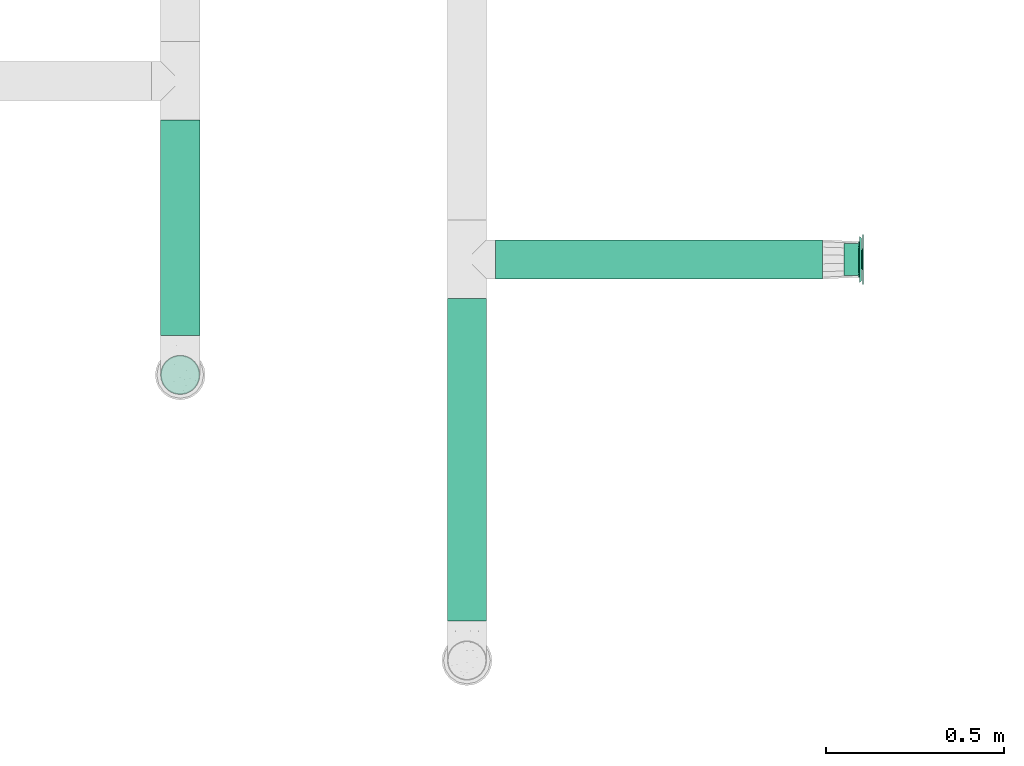
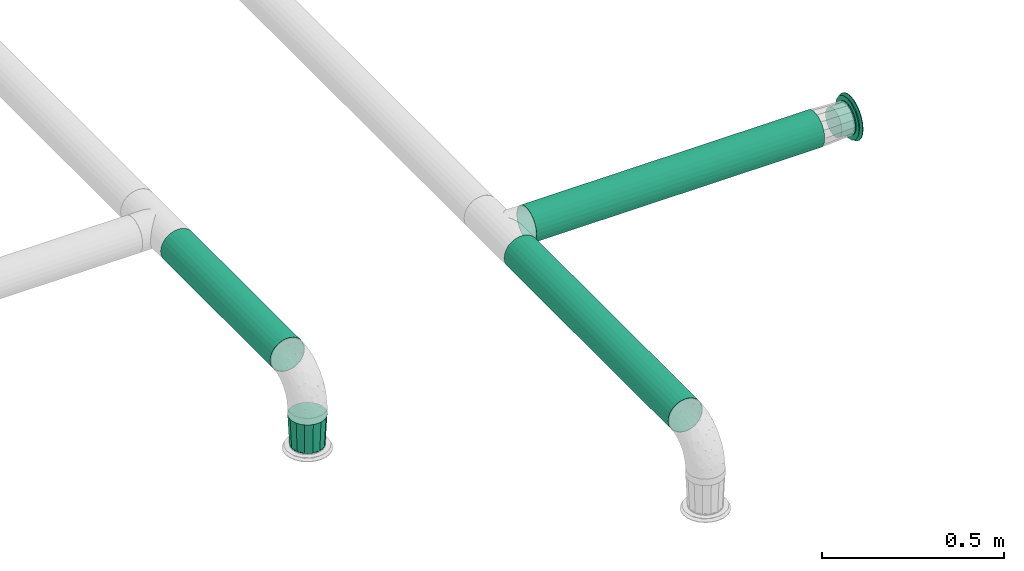
# One storey, part 87 of 123: 3 flow segments, 1 flow fitting, 1 flow terminal.
"""IFC2X3 building model written with IfcOpenShell, lengths in millimetres."""

from ifc_helpers import new_model, entity, si_unit, converted_unit, derived_unit, direction, frame, origin_with_axes, origin_2d_with_axis, place, context, subcontext, project, spatial, hollow_circle, extrude, open_shell, surface_model, source, transform, mapped, material, layer, layer_set, layer_usage, type_object, element, save


model = new_model("IFC2X3")

# Units and contexts
model_context = context("Model", 3, precision=1e-05, world=origin_with_axes(), true_north=direction((0.0, 1.0)))
body_context = subcontext(model_context, "Body", "Model", "MODEL_VIEW")
ifc_project = project(units=[si_unit("AREAUNIT", "SQUARE_METRE"), si_unit("VOLUMEUNIT", "CUBIC_METRE", prefix="DECI"), si_unit("TIMEUNIT", "SECOND"), si_unit("THERMODYNAMICTEMPERATUREUNIT", "DEGREE_CELSIUS"), si_unit("PRESSUREUNIT", "PASCAL"), si_unit("MASSUNIT", "GRAM", prefix="KILO"), si_unit("LENGTHUNIT", "METRE", prefix="MILLI"), si_unit("POWERUNIT", "WATT"), si_unit("ELECTRICCURRENTUNIT", "AMPERE"), si_unit("ELECTRICVOLTAGEUNIT", "VOLT"), derived_unit("VOLUMETRICFLOWRATEUNIT", [(si_unit("VOLUMEUNIT", "CUBIC_METRE", prefix="DECI"), 1), (si_unit("TIMEUNIT", "SECOND"), -1)]), derived_unit("LINEARVELOCITYUNIT", [(si_unit("LENGTHUNIT", "METRE"), 1), (si_unit("TIMEUNIT", "SECOND"), -1)]), derived_unit("MASSDENSITYUNIT", [(si_unit("MASSUNIT", "GRAM", prefix="KILO"), 1), (si_unit("VOLUMEUNIT", "CUBIC_METRE"), -1)]), converted_unit("PLANEANGLEUNIT", "DEGREE", entity("IfcRatioMeasure", 0.01745), si_unit("PLANEANGLEUNIT", "RADIAN"), dimensions=[0, 0, 0, 0, 0, 0, 0])], contexts=[model_context])

# Site, building, storey
site_placement = place(None, origin_with_axes())
site = spatial("IfcSite", under=ifc_project, at=site_placement, CompositionType="ELEMENT")
building_placement = place(site_placement, origin_with_axes())
building = spatial("IfcBuilding", under=site, at=building_placement, Name="mc-building", CompositionType="ELEMENT")
storey_placement = place(building_placement, origin_with_axes())
storey = spatial("IfcBuildingStorey", under=building, at=storey_placement, Name="1. Korrus", CompositionType="ELEMENT", Elevation=0.0)

# Flow fitting
duct_fitting_type = type_object("IfcDuctFittingType", PredefinedType="TRANSITION")
shared_shape_1 = source(origin_with_axes(), body_context, "Body", "SurfaceModel", [
    surface_model("IfcShellBasedSurfaceModel", [(0.0, 12.94095, 48.29629), (0.0, -35.35534, 35.35534), (0.0, 0.0, 50.0), (0.0, 35.35534, 35.35534), (0.0, 25.0, 43.30127), (0.0, 43.30127, 25.0), (0.0, 48.29629, 12.94095), (0.0, -12.94095, 48.29629), (0.0, -25.0, 43.30127), (0.0, -48.29629, 12.94095), (0.0, -43.30127, 25.0), (0.0, -25.0, -43.30127), (0.0, -48.29629, -12.94095), (0.0, -50.0, 0.0), (0.0, 48.29629, -12.94095), (0.0, 12.94095, -48.29629), (0.0, 43.30127, -25.0), (0.0, 35.35534, -35.35534), (0.0, 25.0, -43.30127), (0.0, -35.35534, -35.35534), (0.0, -43.30127, -25.0), (0.0, -12.94095, -48.29629), (0.0, 0.0, -50.0), (0.0, 50.0, 0.0), (100.0, -55.0, 0.0), (100.0, -12.23865, 53.62104), (100.0, -34.29194, 43.00073), (100.0, 49.55329, -23.86361), (100.0, 12.23865, 53.62104), (100.0, 34.29194, 43.00073), (100.0, 55.0, 0.0), (100.0, 49.55329, 23.86361), (100.0, -49.55329, 23.86361), (100.0, 12.23865, -53.62104), (100.0, -49.55329, -23.86361), (100.0, -34.29194, -43.00073), (100.0, 34.29194, -43.00073), (100.0, -12.23865, -53.62104), (0.0, 11.12605, 48.7464), (0.0, -11.12605, 48.7464), (0.0, 31.17449, 39.09157), (0.0, -45.04844, -21.69419), (0.0, -45.04844, 21.69419), (0.0, -31.17449, 39.09157), (0.0, 45.04844, 21.69419), (0.0, 45.04844, -21.69419), (0.0, 31.17449, -39.09157), (0.0, -31.17449, -39.09157), (0.0, -11.12605, -48.7464), (0.0, 11.12605, -48.7464), (0.0, -47.52422, -10.84709), (100.0, -41.92261, -33.43217), (0.0, -38.11147, -30.39288), (100.0, 41.92261, -33.43217), (0.0, 38.11147, -30.39288), (0.0, -21.15027, -43.91899), (100.0, -23.2653, -48.31088), (100.0, -52.32388, -11.72483), (100.0, 0.0, -53.62104), (0.0, 0.0, -48.7464), (100.0, 23.2653, -48.31088), (0.0, 21.15027, -43.91899), (100.0, 52.32388, -11.72483), (0.0, 47.52422, -10.84709), (0.0, 47.52422, 10.84709), (100.0, 41.92261, 33.43217), (0.0, 38.11147, 30.39288), (100.0, -41.92261, 33.43217), (0.0, -38.11147, 30.39288), (0.0, 21.15027, 43.91899), (100.0, 23.2653, 48.31088), (100.0, 52.32388, 11.72483), (100.0, 0.0, 53.62104), (0.0, 0.0, 48.7464), (100.0, -23.2653, 48.31088), (0.0, -21.15027, 43.91899), (100.0, -52.32388, 11.72483), (0.0, -47.52422, 10.84709), (100.0, 27.5, -47.63139), (100.0, 0.0, -55.0), (100.0, 14.23505, -53.12592), (100.0, 38.89087, -38.89087), (100.0, -27.5, -47.63139), (100.0, 47.63139, -27.5), (100.0, 53.12592, -14.23505), (100.0, -14.23505, -53.12592), (100.0, -47.63139, -27.5), (100.0, -38.89087, -38.89087), (100.0, -53.12592, -14.23505), (100.0, 53.12592, 14.23505), (100.0, 47.63139, 27.5), (100.0, 27.5, 47.63139), (100.0, 38.89087, 38.89087), (100.0, 14.23505, 53.12592), (100.0, 0.0, 55.0), (100.0, -47.63139, 27.5), (100.0, -53.12592, 14.23505), (100.0, -27.5, 47.63139), (100.0, -38.89087, 38.89087), (100.0, -14.23505, 53.12592), (98.0, 0.0, 55.0), (98.0, 14.23505, 53.12592), (98.0, 27.5, 47.63139), (98.0, 38.89087, 38.89087), (98.0, 47.63139, 27.5), (98.0, -47.63139, 27.5), (98.0, 53.12592, -14.23505), (98.0, -27.5, 47.63139), (98.0, -14.23505, 53.12592), (98.0, -38.89087, 38.89087), (98.0, -55.0, 0.0), (98.0, -53.12592, 14.23505), (98.0, 53.12592, 14.23505), (98.0, 47.63139, -27.5), (98.0, -27.5, -47.63139), (98.0, 0.0, -55.0), (98.0, 38.89087, -38.89087), (98.0, 27.5, -47.63139), (98.0, 14.23505, -53.12592), (98.0, -47.63139, -27.5), (98.0, -38.89087, -38.89087), (98.0, -53.12592, -14.23505), (98.0, -14.23505, -53.12592), (98.0, 55.0, 0.0), (2.0, 12.94095, -48.29629), (2.0, 25.0, -43.30127), (2.0, 35.35534, -35.35534), (2.0, 43.30127, -25.0), (2.0, 48.29629, -12.94095), (2.0, 0.0, -50.0), (2.0, 50.0, 0.0), (2.0, -25.0, -43.30127), (2.0, -12.94095, -48.29629), (2.0, -35.35534, -35.35534), (2.0, -48.29629, -12.94095), (2.0, -43.30127, -25.0), (2.0, -48.29629, 12.94095), (2.0, 48.29629, 12.94095), (2.0, 43.30127, 25.0), (2.0, 35.35534, 35.35534), (2.0, -35.35534, 35.35534), (2.0, 12.94095, 48.29629), (2.0, 25.0, 43.30127), (2.0, 0.0, 50.0), (2.0, -43.30127, 25.0), (2.0, -50.0, 0.0), (2.0, -12.94095, 48.29629), (2.0, -25.0, 43.30127)], [open_shell([[[0, 1, 2]], [[3, 0, 4]], [[3, 5, 6]], [[0, 3, 1]], [[6, 1, 3]], [[7, 1, 8]], [[7, 2, 1]], [[1, 9, 10]], [[9, 1, 11]], [[12, 13, 9]], [[11, 1, 6]], [[6, 14, 11]], [[15, 14, 16]], [[17, 18, 15]], [[17, 15, 16]], [[11, 14, 15]], [[12, 19, 20]], [[19, 12, 11]], [[15, 21, 11]], [[12, 9, 11]], [[22, 21, 15]], [[14, 6, 23]], [[24, 25, 26]], [[25, 27, 28]], [[29, 28, 27]], [[27, 30, 31]], [[31, 29, 27]], [[24, 26, 32]], [[33, 24, 34]], [[33, 34, 35]], [[36, 27, 33]], [[33, 27, 24]], [[35, 37, 33]], [[24, 27, 25]], [[38, 23, 39]], [[40, 23, 38]], [[41, 42, 43]], [[41, 13, 42]], [[23, 43, 39]], [[40, 44, 23]], [[41, 23, 45]], [[41, 45, 46]], [[47, 41, 48]], [[49, 48, 41]], [[41, 46, 49]], [[23, 41, 43]], [[34, 50, 41]], [[47, 51, 52]], [[45, 27, 53]], [[36, 54, 53]], [[55, 48, 56]], [[34, 57, 50]], [[57, 13, 50]], [[13, 57, 24]], [[55, 35, 47]], [[35, 51, 47]], [[51, 41, 52]], [[58, 59, 49]], [[60, 61, 46]], [[37, 59, 58]], [[62, 63, 23]], [[35, 55, 56]], [[23, 30, 62]], [[53, 54, 45]], [[48, 37, 56]], [[33, 49, 61]], [[49, 33, 58]], [[54, 36, 46]], [[63, 27, 45]], [[34, 41, 51]], [[33, 61, 60]], [[48, 59, 37]], [[27, 63, 62]], [[46, 36, 60]], [[31, 64, 44]], [[40, 65, 66]], [[42, 32, 67]], [[26, 68, 67]], [[69, 38, 70]], [[31, 71, 64]], [[71, 23, 64]], [[23, 71, 30]], [[69, 29, 40]], [[29, 65, 40]], [[65, 44, 66]], [[72, 73, 39]], [[74, 75, 43]], [[28, 73, 72]], [[76, 77, 13]], [[29, 69, 70]], [[13, 24, 76]], [[67, 68, 42]], [[38, 28, 70]], [[25, 39, 75]], [[39, 25, 72]], [[68, 26, 43]], [[77, 32, 42]], [[31, 44, 65]], [[25, 75, 74]], [[38, 73, 28]], [[32, 77, 76]], [[43, 26, 74]], [[78, 79, 80]], [[81, 82, 78]], [[82, 83, 84]], [[81, 83, 82]], [[30, 82, 84]], [[79, 82, 85]], [[79, 78, 82]], [[82, 86, 87]], [[82, 30, 86]], [[24, 88, 86]], [[86, 30, 89]], [[90, 24, 89]], [[91, 90, 92]], [[91, 93, 94]], [[90, 91, 24]], [[94, 95, 91]], [[24, 95, 96]], [[24, 91, 95]], [[94, 97, 98]], [[98, 95, 94]], [[97, 94, 99]], [[89, 24, 86]], [[100, 101, 102]], [[100, 102, 103]], [[100, 104, 105]], [[104, 100, 103]], [[106, 105, 104]], [[100, 107, 108]], [[100, 109, 107]], [[105, 110, 111]], [[109, 100, 105]], [[105, 106, 110]], [[106, 104, 112]], [[106, 113, 110]], [[113, 114, 110]], [[115, 116, 117]], [[113, 116, 115]], [[117, 118, 115]], [[119, 114, 120]], [[121, 110, 119]], [[114, 115, 122]], [[119, 110, 114]], [[115, 114, 113]], [[123, 106, 112]], [[121, 88, 110]], [[119, 86, 121]], [[82, 120, 114]], [[119, 120, 87]], [[85, 114, 122]], [[121, 86, 88]], [[88, 24, 110]], [[85, 82, 114]], [[87, 120, 82]], [[87, 86, 119]], [[79, 85, 122]], [[122, 115, 79]], [[118, 80, 115]], [[117, 78, 118]], [[83, 116, 113]], [[117, 116, 81]], [[84, 113, 106]], [[117, 81, 78]], [[78, 80, 118]], [[30, 84, 106]], [[83, 113, 84]], [[83, 81, 116]], [[123, 30, 106]], [[115, 80, 79]], [[112, 89, 123]], [[104, 90, 112]], [[91, 103, 102]], [[104, 103, 92]], [[93, 102, 101]], [[112, 90, 89]], [[89, 30, 123]], [[93, 91, 102]], [[92, 103, 91]], [[92, 90, 104]], [[94, 93, 101]], [[101, 100, 94]], [[108, 99, 100]], [[107, 97, 108]], [[95, 109, 105]], [[107, 109, 98]], [[96, 105, 111]], [[107, 98, 97]], [[97, 99, 108]], [[24, 96, 111]], [[95, 105, 96]], [[95, 98, 109]], [[110, 24, 111]], [[100, 99, 94]], [[124, 125, 126]], [[124, 126, 127]], [[124, 128, 129]], [[128, 124, 127]], [[129, 128, 130]], [[129, 131, 132]], [[129, 130, 131]], [[133, 134, 135]], [[134, 133, 131]], [[131, 136, 134]], [[131, 130, 137]], [[137, 138, 139]], [[140, 137, 139]], [[140, 139, 141]], [[141, 139, 142]], [[140, 141, 143]], [[136, 140, 144]], [[145, 134, 136]], [[140, 146, 147]], [[131, 140, 136]], [[143, 146, 140]], [[131, 137, 140]], [[12, 134, 13]], [[20, 135, 12]], [[131, 19, 11]], [[20, 19, 133]], [[132, 11, 21]], [[12, 135, 134]], [[134, 145, 13]], [[132, 131, 11]], [[133, 19, 131]], [[133, 135, 20]], [[129, 132, 21]], [[21, 22, 129]], [[15, 124, 22]], [[18, 125, 15]], [[127, 17, 16]], [[18, 17, 126]], [[128, 16, 14]], [[18, 126, 125]], [[125, 124, 15]], [[130, 128, 14]], [[127, 16, 128]], [[127, 126, 17]], [[23, 130, 14]], [[22, 124, 129]], [[6, 137, 23]], [[5, 138, 6]], [[142, 3, 4]], [[5, 3, 139]], [[141, 4, 0]], [[6, 138, 137]], [[137, 130, 23]], [[141, 142, 4]], [[139, 3, 142]], [[139, 138, 5]], [[143, 141, 0]], [[0, 2, 143]], [[7, 146, 2]], [[8, 147, 7]], [[144, 1, 10]], [[8, 1, 140]], [[136, 10, 9]], [[8, 140, 147]], [[147, 146, 7]], [[145, 136, 9]], [[144, 10, 136]], [[144, 140, 1]], [[13, 145, 9]], [[2, 146, 143]]])]),
])
flow_fitting_placement = place(storey_placement, frame((18242.77608, 9054.17592, 2203.1), z_axis=(0.0, 1.0, 0.0), x_axis=(0.0, 0.0, 1.0)))
element("IfcFlowFitting", 1, at=flow_fitting_placement, inside=storey, type_object=duct_fitting_type, context=body_context, shape_type="MappedRepresentation", body=[
    mapped(shared_shape_1, transform((0.0, 0.0, 0.0), scale=1.0)),
])

# Flow terminal
air_terminal_type = type_object("IfcAirTerminalType", Name="100", PredefinedType="NOTDEFINED")
shared_shape_2 = source(origin_with_axes(), body_context, "Body", "SurfaceModel", [
    surface_model("IfcShellBasedSurfaceModel", [(11.2, -70.0, 0.0), (11.2, -67.61481, -18.11733), (11.2, -67.61481, 18.11733), (6.2, -14.64625, -20.15883), (9.2, -22.36867, -22.36867), (6.2, -21.19625, -15.39997), (9.2, 16.375, -28.36233), (6.2, 8.09625, -24.91768), (6.2, 14.64625, -20.15883), (6.2, -8.09625, -24.91768), (9.2, -16.375, -28.36233), (6.2, 21.19625, -15.39997), (9.2, 22.36867, -22.36867), (9.2, -8.1875, -30.55617), (9.2, 8.1875, -30.55617), (9.2, 28.36233, -16.375), (9.2, -28.36233, -16.375), (6.2, 14.64625, 20.15883), (9.2, 22.36867, 22.36867), (6.2, 21.19625, 15.39997), (9.2, -16.375, 28.36233), (6.2, -8.09625, 24.91768), (6.2, -14.64625, 20.15883), (6.2, 8.09625, 24.91768), (9.2, 16.375, 28.36233), (6.2, -21.19625, 15.39997), (9.2, -22.36867, 22.36867), (9.2, 8.1875, 30.55617), (9.2, -8.1875, 30.55617), (9.2, -28.36233, 16.375), (9.2, 28.36233, 16.375), (6.2, -53.11211, -25.57744), (6.2, -36.75472, -46.08897), (6.2, -13.11761, -57.472), (6.2, 13.11761, -57.472), (6.2, 36.75472, -46.08897), (6.2, 53.11211, -25.57744), (0.0, -12.53288, -63.00706), (6.2, 0.0, -57.472), (0.0, -46.3155, -46.3155), (0.0, -35.69063, -53.4148), (0.0, 0.0, -65.5), (6.2, 44.93342, -35.83321), (0.0, 46.3155, -46.3155), (0.0, 35.69063, -53.4148), (6.2, -44.93342, -35.83321), (0.0, 12.53288, -63.00706), (0.0, 25.06576, -60.51411), (6.2, 56.03105, -12.78872), (0.0, 60.51411, -25.06576), (0.0, 63.00706, -12.53288), (0.0, 53.4148, -35.69063), (0.0, -25.06576, -60.51411), (0.0, -63.00706, -12.53288), (0.0, -60.51411, -25.06576), (6.2, -56.03105, -12.78872), (0.0, -53.4148, -35.69063), (6.2, 13.11761, 57.472), (0.0, 12.53288, 63.00706), (6.2, 0.0, 57.472), (6.2, 36.75472, 46.08897), (0.0, 46.3155, 46.3155), (0.0, 35.69063, 53.4148), (0.0, 0.0, 65.5), (6.2, -44.93342, 35.83321), (6.2, -36.75472, 46.08897), (0.0, -46.3155, 46.3155), (0.0, -35.69063, 53.4148), (6.2, 44.93342, 35.83321), (0.0, -12.53288, 63.00706), (0.0, -25.06576, 60.51411), (6.2, -13.11761, 57.472), (6.2, -56.03105, 12.78872), (0.0, -60.51411, 25.06576), (0.0, -63.00706, 12.53288), (0.0, -53.4148, 35.69063), (0.0, 25.06576, 60.51411), (0.0, 63.00706, 12.53288), (0.0, 60.51411, 25.06576), (6.2, 56.03105, 12.78872), (0.0, 53.4148, 35.69063), (-3.1, 43.30127, 25.0), (-3.1, -48.29629, -12.94095), (-3.1, -43.30127, 25.0), (-3.1, 25.0, -43.30127), (-3.1, 48.29629, -12.94095), (-3.1, 35.35534, -35.35534), (-3.1, -35.35534, -35.35534), (-3.1, -25.0, -43.30127), (-43.1, 43.46666, 11.64686), (-3.1, 38.97115, 22.5), (-3.1, 43.46666, 11.64686), (-3.1, 45.0, 0.0), (-43.1, 45.0, 0.0), (-3.1, 31.81981, 31.81981), (-43.1, 38.97115, 22.5), (-43.1, -38.97115, 22.5), (-3.1, -38.97115, 22.5), (-3.1, -31.81981, 31.81981), (-3.1, -43.46666, 11.64686), (-43.1, -43.46666, 11.64686), (-43.1, -45.0, 0.0), (-3.1, -45.0, 0.0), (-43.1, -43.46666, -11.64686), (-3.1, -38.97115, -22.5), (-3.1, -43.46666, -11.64686), (-3.1, -11.64686, -43.46666), (-3.1, -22.5, -38.97115), (-43.1, -22.5, -38.97115), (-3.1, -31.81981, -31.81981), (-43.1, -38.97115, -22.5), (-43.1, 22.5, -38.97115), (-3.1, 22.5, -38.97115), (-3.1, 11.64686, -43.46666), (-43.1, 38.97115, -22.5), (-3.1, 38.97115, -22.5), (-3.1, 31.81981, -31.81981), (-3.1, 43.46666, -11.64686), (-43.1, 43.46666, -11.64686), (11.2, -49.49747, -49.49747), (11.2, -35.0, -60.62178), (11.2, -18.11733, -67.61481), (11.2, 67.61481, 18.11733), (11.2, -60.62178, -35.0), (11.2, 18.11733, -67.61481), (11.2, 35.0, -60.62178), (11.2, 0.0, -70.0), (11.2, 60.62178, -35.0), (11.2, 67.61481, -18.11733), (11.2, 49.49747, -49.49747), (11.2, -49.49747, 49.49747), (11.2, -60.62178, 35.0), (11.2, -35.0, 60.62178), (11.2, -18.11733, 67.61481), (11.2, 0.0, 70.0), (11.2, 60.62178, 35.0), (11.2, 49.49747, 49.49747), (11.2, 70.0, 0.0), (11.2, 35.0, 60.62178), (11.2, 18.11733, 67.61481), (9.2, -49.49747, 49.49747), (9.2, -35.0, 60.62178), (9.2, -18.11733, 67.61481), (9.2, -67.61481, 18.11733), (9.2, -70.0, 0.0), (9.2, -60.62178, 35.0), (9.2, 67.61481, 18.11733), (9.2, 35.0, 60.62178), (9.2, 18.11733, 67.61481), (9.2, 0.0, 70.0), (9.2, 60.62178, 35.0), (9.2, 49.49747, 49.49747), (9.2, -67.61481, -18.11733), (9.2, -49.49747, -49.49747), (9.2, -60.62178, -35.0), (9.2, -18.11733, -67.61481), (9.2, 70.0, 0.0), (9.2, -35.0, -60.62178), (9.2, 0.0, -70.0), (9.2, 60.62178, -35.0), (9.2, 49.49747, -49.49747), (9.2, 67.61481, -18.11733), (9.2, 35.0, -60.62178), (9.2, 18.11733, -67.61481), (9.2, -32.75, 0.0), (9.2, 0.0, 32.75), (9.2, 32.75, 0.0), (9.2, 0.0, -32.75), (6.2, 26.2, 0.0), (6.2, -26.2, 0.0), (9.2, -31.06579, -6.28555), (6.2, -23.69812, -7.69999), (6.2, 23.69812, -7.69999), (9.2, 31.06579, -6.28555), (6.2, 0.0, -24.91768), (9.2, 31.06579, 6.28555), (6.2, 23.69812, 7.69999), (6.2, -23.69812, 7.69999), (9.2, -31.06579, 6.28555), (6.2, 0.0, 24.91768), (6.2, 53.11211, 25.57744), (6.2, 58.95, 0.0), (6.2, -53.11211, 25.57744), (6.2, -58.95, 0.0), (0.0, 65.5, 0.0), (0.0, -65.5, 0.0), (6.2, -24.93616, -51.78048), (6.2, 24.93616, -51.78048), (6.2, 24.93616, 51.78048), (6.2, -24.93616, 51.78048), (-3.1, 0.0, 50.0), (-3.1, 35.35534, 35.35534), (-3.1, -12.94095, 48.29629), (-3.1, -25.0, 43.30127), (-3.1, -35.35534, 35.35534), (-3.1, 25.0, 43.30127), (-3.1, 12.94095, 48.29629), (-3.1, 48.29629, 12.94095), (-3.1, 50.0, 0.0), (-3.1, -50.0, 0.0), (-3.1, -48.29629, 12.94095), (-3.1, -43.30127, -25.0), (-3.1, -12.94095, -48.29629), (-3.1, 0.0, -50.0), (-3.1, 43.30127, -25.0), (-3.1, 12.94095, -48.29629), (0.0, -12.94095, -48.29629), (0.0, 0.0, -50.0), (0.0, -25.0, -43.30127), (0.0, -35.35534, -35.35534), (0.0, -48.29629, -12.94095), (0.0, 25.0, -43.30127), (0.0, -43.30127, -25.0), (0.0, 43.30127, 25.0), (0.0, 12.94095, -48.29629), (0.0, 43.30127, -25.0), (0.0, 48.29629, -12.94095), (0.0, 35.35534, -35.35534), (0.0, 50.0, 0.0), (0.0, -50.0, 0.0), (0.0, -48.29629, 12.94095), (0.0, -43.30127, 25.0), (0.0, -35.35534, 35.35534), (0.0, -12.94095, 48.29629), (0.0, -25.0, 43.30127), (0.0, 35.35534, 35.35534), (0.0, 0.0, 50.0), (0.0, 48.29629, 12.94095), (0.0, 25.0, 43.30127), (0.0, 12.94095, 48.29629), (-43.1, -22.5, 38.97115), (-43.1, -11.64686, 43.46666), (-43.1, 0.0, 45.0), (-43.1, 11.64686, 43.46666), (-43.1, -31.81981, 31.81981), (-43.1, 31.81981, 31.81981), (-43.1, 22.5, 38.97115), (-43.1, -31.81981, -31.81981), (-43.1, 31.81981, -31.81981), (-43.1, -11.64686, -43.46666), (-43.1, 11.64686, -43.46666), (-43.1, 0.0, -45.0), (-3.1, 0.0, -45.0), (-3.1, 0.0, 45.0), (-3.1, -22.5, 38.97115), (-3.1, -11.64686, 43.46666), (-3.1, 11.64686, 43.46666), (-3.1, 22.5, 38.97115)], [open_shell([[[0, 1, 2]], [[3, 4, 5]], [[6, 7, 8]], [[3, 9, 10]], [[4, 3, 10]], [[11, 12, 8]], [[13, 10, 9]], [[7, 6, 14]], [[6, 8, 12]], [[12, 11, 15]], [[16, 5, 4]], [[17, 18, 19]], [[20, 21, 22]], [[17, 23, 24]], [[18, 17, 24]], [[25, 26, 22]], [[27, 24, 23]], [[21, 20, 28]], [[20, 22, 26]], [[26, 25, 29]], [[30, 19, 18]], [[31, 32, 33]], [[34, 35, 36]], [[33, 37, 38]], [[32, 39, 40]], [[41, 38, 37]], [[42, 35, 43]], [[44, 43, 35]], [[39, 32, 45]], [[46, 47, 34]], [[48, 49, 50]], [[38, 46, 34]], [[42, 43, 51]], [[33, 52, 37]], [[53, 54, 55]], [[46, 38, 41]], [[56, 39, 45]], [[57, 58, 59]], [[60, 61, 62]], [[63, 59, 58]], [[64, 65, 66]], [[67, 66, 65]], [[61, 60, 68]], [[69, 70, 71]], [[72, 73, 74]], [[59, 69, 71]], [[64, 66, 75]], [[57, 76, 58]], [[77, 78, 79]], [[69, 59, 63]], [[80, 61, 68]], [[81, 82, 83]], [[84, 85, 86]], [[87, 82, 88]], [[89, 90, 91]], [[91, 92, 93]], [[94, 90, 95]], [[96, 97, 98]], [[99, 97, 100]], [[101, 102, 99]], [[103, 104, 105]], [[105, 102, 101]], [[106, 107, 108]], [[109, 104, 110]], [[111, 112, 113]], [[114, 115, 116]], [[117, 115, 118]], [[93, 92, 117]], [[119, 120, 121]], [[1, 119, 121]], [[122, 1, 121]], [[123, 119, 1]], [[124, 122, 121]], [[125, 122, 124]], [[121, 126, 124]], [[127, 128, 129]], [[129, 128, 122]], [[129, 122, 125]], [[130, 131, 2]], [[132, 130, 2]], [[122, 133, 2]], [[132, 2, 133]], [[134, 133, 122]], [[135, 136, 122]], [[122, 128, 137]], [[136, 138, 122]], [[139, 122, 138]], [[122, 139, 134]], [[2, 1, 122]], [[140, 141, 142]], [[143, 140, 142]], [[142, 144, 143]], [[145, 140, 143]], [[146, 144, 142]], [[147, 146, 148]], [[149, 148, 146]], [[150, 146, 151]], [[147, 151, 146]], [[146, 142, 149]], [[146, 152, 144]], [[153, 154, 152]], [[155, 153, 152]], [[146, 156, 155]], [[157, 153, 155]], [[158, 155, 156]], [[159, 160, 161]], [[156, 161, 160]], [[160, 162, 156]], [[163, 156, 162]], [[163, 158, 156]], [[152, 146, 155]], [[156, 128, 161]], [[161, 127, 159]], [[162, 160, 125]], [[129, 160, 159]], [[163, 162, 124]], [[128, 127, 161]], [[156, 137, 128]], [[162, 125, 124]], [[125, 160, 129]], [[159, 127, 129]], [[163, 124, 126]], [[126, 158, 163]], [[158, 121, 155]], [[155, 120, 157]], [[154, 153, 123]], [[119, 153, 157]], [[152, 154, 1]], [[120, 119, 157]], [[155, 121, 120]], [[152, 1, 0]], [[1, 154, 123]], [[153, 119, 123]], [[152, 0, 144]], [[126, 121, 158]], [[144, 2, 143]], [[143, 131, 145]], [[141, 140, 132]], [[130, 140, 145]], [[142, 141, 133]], [[2, 131, 143]], [[144, 0, 2]], [[141, 132, 133]], [[132, 140, 130]], [[145, 131, 130]], [[142, 133, 134]], [[134, 149, 142]], [[149, 139, 148]], [[148, 138, 147]], [[150, 151, 135]], [[136, 151, 147]], [[146, 150, 122]], [[138, 136, 147]], [[148, 139, 138]], [[146, 122, 137]], [[122, 150, 135]], [[151, 136, 135]], [[146, 137, 156]], [[134, 139, 149]], [[30, 24, 164]], [[24, 20, 164]], [[165, 20, 24]], [[164, 20, 29]], [[166, 30, 16]], [[16, 6, 166]], [[167, 6, 10]], [[30, 164, 16]], [[10, 6, 16]], [[6, 15, 166]], [[21, 19, 11]], [[23, 19, 21]], [[11, 19, 168]], [[7, 25, 21]], [[7, 5, 169]], [[21, 11, 7]], [[9, 5, 7]], [[169, 25, 7]], [[170, 164, 169]], [[170, 171, 16]], [[11, 172, 15]], [[172, 168, 173]], [[174, 13, 9]], [[166, 173, 168]], [[172, 173, 15]], [[169, 171, 170]], [[5, 16, 171]], [[167, 174, 14]], [[174, 167, 13]], [[14, 174, 7]], [[175, 166, 168]], [[175, 176, 30]], [[25, 177, 29]], [[177, 169, 178]], [[179, 27, 23]], [[164, 178, 169]], [[177, 178, 29]], [[168, 176, 175]], [[19, 30, 176]], [[165, 179, 28]], [[179, 165, 27]], [[28, 179, 21]], [[180, 60, 57]], [[181, 180, 65]], [[65, 57, 71]], [[180, 57, 65]], [[65, 182, 181]], [[182, 36, 181]], [[183, 34, 36]], [[31, 34, 183]], [[31, 33, 34]], [[182, 183, 36]], [[70, 63, 49]], [[70, 73, 66]], [[49, 63, 184]], [[78, 76, 61]], [[76, 78, 184]], [[184, 63, 76]], [[73, 70, 49]], [[39, 54, 185]], [[41, 39, 185]], [[52, 39, 41]], [[43, 185, 49]], [[185, 43, 47]], [[185, 47, 41]], [[73, 49, 185]], [[55, 54, 31]], [[31, 54, 56]], [[52, 186, 40]], [[53, 55, 183]], [[56, 45, 31]], [[185, 53, 183]], [[32, 40, 186]], [[33, 186, 52]], [[44, 35, 187]], [[49, 36, 51]], [[34, 47, 187]], [[42, 51, 36]], [[187, 47, 44]], [[49, 48, 36]], [[48, 50, 181]], [[184, 181, 50]], [[79, 78, 180]], [[180, 78, 80]], [[76, 188, 62]], [[77, 79, 181]], [[80, 68, 180]], [[184, 77, 181]], [[60, 62, 188]], [[57, 188, 76]], [[67, 65, 189]], [[73, 182, 75]], [[71, 70, 189]], [[64, 75, 182]], [[189, 70, 67]], [[73, 72, 182]], [[72, 74, 183]], [[185, 183, 74]], [[190, 191, 192]], [[193, 192, 194]], [[83, 192, 81]], [[194, 192, 83]], [[195, 191, 196]], [[191, 190, 196]], [[197, 198, 81]], [[81, 192, 191]], [[198, 84, 81]], [[199, 200, 83]], [[81, 88, 82]], [[201, 82, 87]], [[88, 81, 202]], [[81, 203, 202]], [[204, 86, 85]], [[205, 203, 84]], [[84, 198, 85]], [[81, 84, 203]], [[199, 83, 82]], [[206, 207, 208]], [[209, 208, 210]], [[210, 208, 211]], [[212, 209, 210]], [[210, 211, 213]], [[214, 211, 207]], [[211, 208, 207]], [[215, 216, 217]], [[211, 217, 216]], [[216, 218, 211]], [[219, 210, 220]], [[221, 210, 213]], [[222, 221, 223]], [[213, 223, 221]], [[224, 222, 223]], [[223, 225, 226]], [[227, 213, 218]], [[218, 213, 211]], [[228, 229, 225]], [[223, 213, 225]], [[226, 225, 229]], [[221, 220, 210]], [[199, 220, 200]], [[200, 221, 83]], [[193, 194, 224]], [[222, 194, 83]], [[192, 193, 223]], [[220, 221, 200]], [[199, 219, 220]], [[193, 224, 223]], [[224, 194, 222]], [[83, 221, 222]], [[192, 223, 226]], [[226, 190, 192]], [[190, 229, 196]], [[196, 228, 195]], [[81, 191, 213]], [[225, 191, 195]], [[197, 81, 227]], [[228, 225, 195]], [[196, 229, 228]], [[197, 227, 218]], [[227, 81, 213]], [[191, 225, 213]], [[197, 218, 198]], [[226, 229, 190]], [[198, 216, 85]], [[85, 215, 204]], [[84, 86, 211]], [[217, 86, 204]], [[205, 84, 214]], [[216, 215, 85]], [[198, 218, 216]], [[84, 211, 214]], [[211, 86, 217]], [[204, 215, 217]], [[205, 214, 207]], [[207, 203, 205]], [[203, 206, 202]], [[202, 208, 88]], [[201, 87, 212]], [[209, 87, 88]], [[82, 201, 210]], [[208, 209, 88]], [[202, 206, 208]], [[82, 210, 219]], [[210, 201, 212]], [[87, 209, 212]], [[82, 219, 199]], [[207, 206, 203]], [[230, 231, 232]], [[230, 232, 233]], [[230, 100, 96]], [[234, 230, 96]], [[100, 230, 233]], [[235, 89, 236]], [[100, 233, 236]], [[95, 89, 235]], [[118, 89, 93]], [[118, 236, 89]], [[118, 100, 236]], [[110, 103, 101]], [[237, 110, 101]], [[238, 108, 101]], [[237, 101, 108]], [[239, 108, 238]], [[114, 238, 118]], [[238, 101, 118]], [[240, 241, 111]], [[238, 111, 241]], [[238, 241, 239]], [[100, 118, 101]], [[106, 242, 107]], [[107, 112, 109]], [[102, 105, 104]], [[112, 104, 109]], [[92, 104, 117]], [[113, 112, 242]], [[112, 107, 242]], [[115, 117, 116]], [[112, 116, 117]], [[112, 117, 104]], [[92, 102, 104]], [[97, 99, 243]], [[98, 97, 244]], [[243, 245, 244]], [[97, 243, 244]], [[246, 243, 99]], [[90, 94, 91]], [[92, 91, 247]], [[94, 247, 91]], [[247, 99, 92]], [[247, 246, 99]], [[102, 92, 99]], [[101, 99, 100]], [[100, 97, 96]], [[230, 234, 244]], [[98, 234, 96]], [[231, 230, 245]], [[245, 230, 244]], [[244, 234, 98]], [[245, 243, 231]], [[243, 232, 231]], [[236, 233, 246]], [[236, 247, 235]], [[89, 95, 90]], [[94, 95, 235]], [[93, 89, 91]], [[232, 246, 233]], [[246, 247, 236]], [[243, 246, 232]], [[247, 94, 235]], [[93, 117, 118]], [[118, 115, 114]], [[111, 238, 112]], [[116, 238, 114]], [[240, 111, 113]], [[112, 238, 116]], [[240, 113, 242]], [[242, 241, 240]], [[108, 239, 106]], [[108, 107, 237]], [[103, 110, 104]], [[109, 110, 237]], [[101, 103, 105]], [[241, 106, 239]], [[242, 106, 241]], [[107, 109, 237]]])]),
])
flow_terminal_placement = place(storey_placement, frame((20145.40649, 9377.68544, 2435.0), z_axis=(0.0, 0.0, 1.0), x_axis=(1.0, 0.0, 0.0)))
element("IfcFlowTerminal", 2, at=flow_terminal_placement, inside=storey, type_object=air_terminal_type, Name="100", context=body_context, shape_type="MappedRepresentation", body=[
    mapped(shared_shape_2, transform((0.0, 0.0, 0.0), scale=1.0)),
])

# Flow segments
ifc_material = material(Name="FZ1")
ifc_layer = layer(ifc_material, 0.0)
ifc_layer_set = layer_set([ifc_layer], Name="FZ1")
ifc_layer_usage = layer_usage(ifc_layer_set, "AXIS1", "POSITIVE", 0.0)
duct_segment_type = type_object("IfcDuctSegmentType", PredefinedType="RIGIDSEGMENT")
shared_shape_3 = source(origin_with_axes(), body_context, "Body", "SweptSolid", [
    extrude(hollow_circle(Radius=55.0, WallThickness=2.0, at=origin_2d_with_axis()), frame((0.0, 0.0, 0.0), z_axis=(1.0, 0.0, 0.0), x_axis=(0.0, 1.0, 0.0)), (0.0, 0.0, 1.0), 603.5),
])
flow_segment_1_placement = place(storey_placement, frame((18242.77608, 9767.62755, 2435.0), z_axis=(0.0, 0.0, 1.0), x_axis=(0.0, -1.0, 0.0)))
element("IfcFlowSegment", 3, at=flow_segment_1_placement, inside=storey, type_object=duct_segment_type, material=ifc_layer_usage, context=body_context, shape_type="MappedRepresentation", body=[
    mapped(shared_shape_3, transform((0.0, 0.0, 0.0), scale=1.0)),
])
shared_shape_4 = source(origin_with_axes(), body_context, "Body", "SweptSolid", [
    extrude(hollow_circle(Radius=55.0, WallThickness=2.0, at=origin_2d_with_axis()), frame((0.0, 0.0, 0.0), z_axis=(1.0, 0.0, 0.0), x_axis=(0.0, 1.0, 0.0)), (0.0, 0.0, 1.0), 903.5),
])
flow_segment_2_placement = place(storey_placement, frame((19046.0369, 9267.68544, 2435.0), z_axis=(0.0, 0.0, 1.0), x_axis=(0.0, -1.0, 0.0)))
element("IfcFlowSegment", 4, at=flow_segment_2_placement, inside=storey, type_object=duct_segment_type, material=ifc_layer_usage, context=body_context, shape_type="MappedRepresentation", body=[
    mapped(shared_shape_4, transform((0.0, 0.0, 0.0), scale=1.0)),
])
shared_shape_5 = source(origin_with_axes(), body_context, "Body", "SweptSolid", [
    extrude(hollow_circle(Radius=55.0, WallThickness=2.0, at=origin_2d_with_axis()), frame((0.0, 0.0, 0.0), z_axis=(1.0, 0.0, 0.0), x_axis=(0.0, 1.0, 0.0)), (0.0, 0.0, 1.0), 916.3),
])
flow_segment_3_placement = place(storey_placement, frame((19126.0369, 9377.68544, 2435.0), z_axis=(0.0, 0.0, 1.0), x_axis=(1.0, 0.0, 0.0)))
element("IfcFlowSegment", 5, at=flow_segment_3_placement, inside=storey, type_object=duct_segment_type, material=ifc_layer_usage, context=body_context, shape_type="MappedRepresentation", body=[
    mapped(shared_shape_5, transform((0.0, 0.0, 0.0), scale=1.0)),
])

save(model, "model.ifc")
